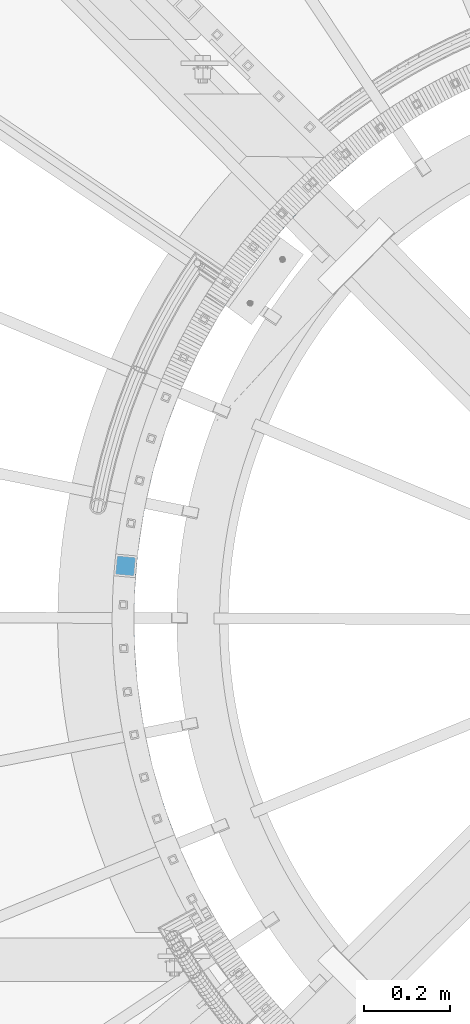
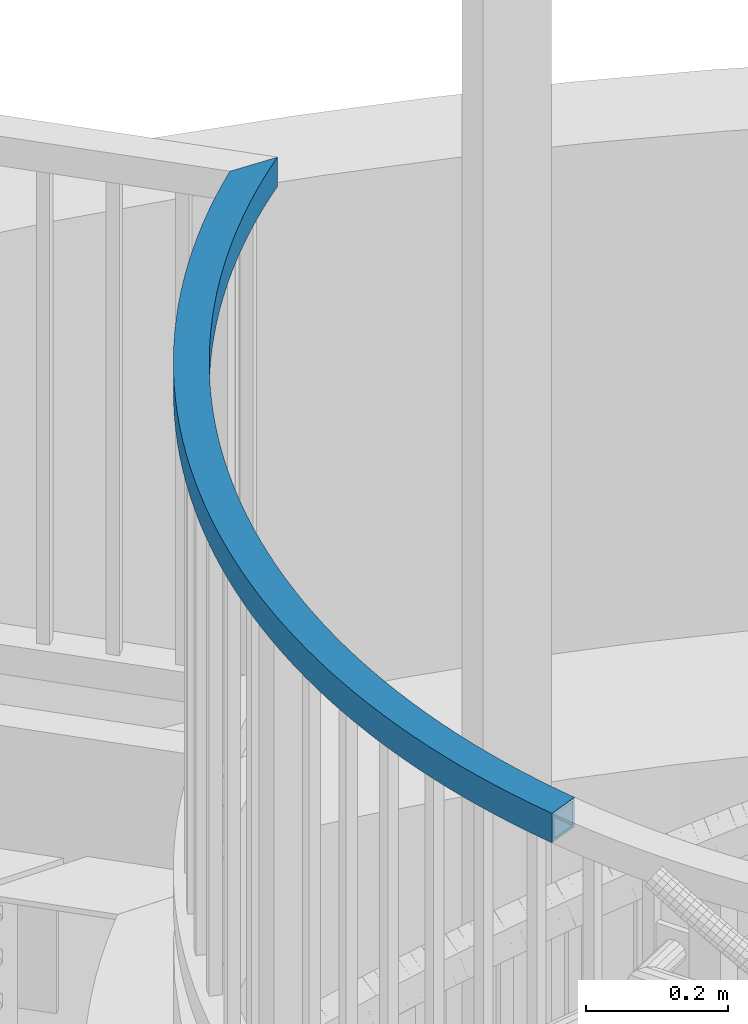
# One storey, part 344 of 975: 1 beam.
"""IFC2X3 building model written with IfcOpenShell, lengths in millimetres."""

from ifc_helpers import new_model, si_unit, frame, origin_with_axes, place, context, subcontext, project, spatial, faceted_brep, material, type_object, element, save


model = new_model("IFC2X3")

# Units and contexts
model_context = context("Model", 3, precision=1e-05, world=origin_with_axes())
body_context = subcontext(model_context, "Body", "Model", "MODEL_VIEW")
ifc_project = project(units=[si_unit("LENGTHUNIT", "METRE", prefix="MILLI"), si_unit("AREAUNIT", "SQUARE_METRE"), si_unit("VOLUMEUNIT", "CUBIC_METRE"), si_unit("MASSUNIT", "GRAM", prefix="KILO"), si_unit("TIMEUNIT", "SECOND"), si_unit("PLANEANGLEUNIT", "RADIAN"), si_unit("SOLIDANGLEUNIT", "STERADIAN"), si_unit("THERMODYNAMICTEMPERATUREUNIT", "DEGREE_CELSIUS"), si_unit("LUMINOUSINTENSITYUNIT", "LUMEN")], contexts=[model_context])

# Site, building, storey
site_placement = place(None, origin_with_axes())
site = spatial("IfcSite", under=ifc_project, at=site_placement, CompositionType="ELEMENT")
building_placement = place(site_placement, origin_with_axes())
building = spatial("IfcBuilding", under=site, at=building_placement, Name="Undefined", CompositionType="ELEMENT")
storey_placement = place(building_placement, origin_with_axes())
storey = spatial("IfcBuildingStorey", under=building, at=storey_placement, Name="Undefined", CompositionType="ELEMENT", Elevation=0.0)

# Beam
ifc_material = material()
beam_type = type_object("IfcBeamType", Name="HSS2X2X.188_TUBES", PredefinedType="NOTDEFINED")
beam_placement = place(storey_placement, frame((33433.8380151648, 2893.80847219142, 5130.8), z_axis=(0.0, 0.0, 1.0), x_axis=(0.321150340924358, 0.947028224776943, 0.0)))
element("IfcBeam", 1, at=beam_placement, inside=storey, type_object=beam_type, material=ifc_material, Name="HANDRAIL", ObjectType="HSS2X2X.188_TUBES", context=body_context, shape_type="Brep", body=[
    faceted_brep([(1598.93336407452, 112.409592941978, 25.3999999999996), (1598.93336407452, 112.409592941978, -25.3999999999996), (1626.76418138744, 95.4936685589528, -25.3999999999996), (1626.76418138744, 95.4936685589528, 25.3999999999996), (1570.70875476768, 128.659956615276, 25.3999999999996), (1570.70875476768, 128.659956615276, -25.3999999999996), (1542.10626700468, 144.23559733418, 25.3999999999996), (1542.10626700468, 144.23559733418, -25.3999999999996), (1513.14202737783, 159.127733274894, 25.3999999999996), (1513.14202737783, 159.127733274894, -25.3999999999996), (1483.83236644166, 173.327967985762, 25.3999999999996), (1483.83236644166, 173.327967985762, -25.3999999999996), (1454.19380950532, 186.828295121384, 25.3999999999996), (1454.19380950532, 186.828295121384, -25.3999999999996), (1424.24306731543, 199.62110295672, 25.3999999999996), (1424.24306731543, 199.62110295672, -25.3999999999996), (1393.9970266342, 211.699178678729, 25.3999999999996), (1393.9970266342, 211.699178678729, -25.3999999999996), (1363.47274071841, 223.055712453068, 25.3999999999996), (1363.47274071841, 223.055712453068, -25.3999999999996), (1332.68741970443, 233.684301263602, 25.3999999999996), (1332.68741970443, 233.684301263602, -25.3999999999996), (1301.65842090491, 243.578952522545, 25.3999999999996), (1301.65842090491, 243.578952522545, -25.3999999999996), (1270.40323902235, 252.734087449178, 25.3999999999996), (1270.40323902235, 252.734087449178, -25.3999999999996), (1238.93949628531, 261.144544215262, 25.3999999999996), (1238.93949628531, 261.144544215262, -25.3999999999996), (1207.28493251269, 268.805580855405, 25.3999999999996), (1207.28493251269, 268.805580855405, -25.3999999999996), (1175.45739511167, 275.712877940594, 25.3999999999996), (1175.45739511167, 275.712877940594, -25.3999999999996), (1143.47482901506, 281.862541013641, 25.3999999999996), (1143.47482901506, 281.862541013641, -25.3999999999996), (1111.35526656359, 287.251102784918, 25.3999999999996), (1111.35526656359, 287.251102784918, -25.3999999999996), (1079.11681733901, 291.875525087253, 25.3999999999996), (1079.11681733901, 291.875525087253, -25.3999999999996), (1046.77765795353, 295.733200588944, 25.3999999999996), (1046.77765795353, 295.733200588944, -25.3999999999996), (1014.35602180154, 298.8219542638, 25.3999999999996), (1014.35602180154, 298.8219542638, -25.3999999999996), (981.87018877931, 301.140044617438, 25.3999999999996), (981.87018877931, 301.140044617438, -25.3999999999996), (949.338474978445, 302.686164669216, 25.3999999999996), (949.338474978445, 302.686164669216, -25.3999999999996), (916.77922235896, 303.45944268908, 25.3999999999996), (916.77922235896, 303.45944268908, -25.3999999999996), (884.210788407729, 303.459442689124, 25.3999999999996), (884.210788407729, 303.459442689124, -25.3999999999996), (851.651535788242, 302.686164669329, 25.3999999999996), (851.651535788242, 302.686164669329, -25.3999999999996), (819.11982198738, 301.14004461763, 25.3999999999996), (819.11982198738, 301.14004461763, -25.3999999999996), (786.633988965152, 298.821954264073, 25.3999999999996), (786.633988965152, 298.821954264073, -25.3999999999996), (754.212352813165, 295.733200589297, 25.3999999999996), (754.212352813165, 295.733200589297, -25.3999999999996), (721.873193427688, 291.875525087682, 25.3999999999996), (721.873193427688, 291.875525087682, -25.3999999999996), (689.634744203111, 287.25110278542, 25.3999999999996), (689.634744203111, 287.25110278542, -25.3999999999996), (657.515181751656, 281.862541014216, 25.3999999999996), (657.515181751656, 281.862541014216, -25.3999999999996), (625.532615655047, 275.712877941245, 25.3999999999996), (625.532615655047, 275.712877941245, -25.3999999999996), (593.705078254034, 268.805580856129, 25.3999999999996), (593.705078254034, 268.805580856129, -25.3999999999996), (562.050514481421, 261.144544216066, 25.3999999999996), (562.050514481421, 261.144544216066, -25.3999999999996), (530.586771744394, 252.734087450059, 25.3999999999996), (530.586771744394, 252.734087450059, -25.3999999999996), (499.331589861844, 243.578952523494, 25.3999999999996), (499.331589861844, 243.578952523494, -25.3999999999996), (468.302591062333, 233.684301264624, 25.3999999999996), (468.302591062333, 233.684301264624, -25.3999999999996), (437.517270048369, 223.055712454166, 25.3999999999996), (437.517270048369, 223.055712454166, -25.3999999999996), (406.992984132585, 211.699178679897, 25.3999999999996), (406.992984132585, 211.699178679897, -25.3999999999996), (376.74694345137, 199.621102957961, 25.3999999999996), (376.74694345137, 199.621102957961, -25.3999999999996), (346.796201261493, 186.828295122694, 25.3999999999996), (346.796201261493, 186.828295122694, -25.3999999999996), (317.157644325169, 173.327967987148, 25.3999999999996), (317.157644325169, 173.327967987148, -25.3999999999996), (287.847983389005, 159.127733276349, 25.3999999999996), (287.847983389005, 159.127733276349, -25.3999999999996), (258.883743762184, 144.235597335708, 25.3999999999996), (258.883743762184, 144.235597335708, -25.3999999999996), (230.281255999194, 128.659956616866, 25.3999999999996), (230.281255999194, 128.659956616866, -25.3999999999996), (202.056646692379, 112.409592943641, 25.3999999999996), (202.056646692379, 112.409592943641, -25.3999999999996), (174.225829379473, 95.4936685606808, 25.3999999999996), (174.225829379473, 95.4936685606808, -25.3999999999996), (146.804495571261, 77.9217209676208, 25.3999999999996), (146.804495571261, 77.9217209676208, -25.3999999999996), (119.808105904445, 59.7036575416751, 25.3999999999996), (119.808105904445, 59.7036575416751, -25.3999999999996), (93.2518814246323, 40.8497499516743, 25.3999999999996), (93.2518814246323, 40.8497499516743, -25.3999999999996), (67.1507950044543, 21.3706283667307, 25.3999999999996), (67.1507950044543, 21.3706283667307, -25.3999999999996), (41.5195629016052, 1.27727546274036, 25.3999999999996), (41.5195629016052, 1.27727546274036, -25.3999999999996), (16.3726364615322, -19.4189797698346, 25.3999999999996), (16.3726364615322, -19.4189797698346, -25.3999999999996), (-16.3726364615268, 19.4189797698236, -25.3999999999996), (9.70565762447586, 40.8817629739824, -25.3999999999996), (36.2861946200246, 61.719314133672, -25.3999999999996), (63.3539879446489, 81.9198846662111, -25.3999999999996), (90.8937762940877, 101.47208512991, -25.3999999999996), (118.890032244861, 120.36489164571, -25.3999999999996), (147.326971008932, 138.587652112579, -25.3999999999996), (176.188559333428, 156.130092213429, -25.3999999999996), (205.458524540496, 172.982321207885, -25.3999999999996), (235.120363702115, 189.134837508904, -25.3999999999996), (265.157352944745, 204.578534039942, -25.3999999999996), (295.552556878542, 219.304703369657, -25.3999999999996), (326.28883814584, 233.305042621338, -25.3999999999996), (357.34886708349, 246.571658154207, -25.3999999999996), (388.715131493642, 259.097070013991, -25.3999999999996), (420.369946517416, 270.874216150271, -25.3999999999996), (452.295464605973, 281.896456398157, -25.3999999999996), (484.473685583242, 292.157576222173, -25.3999999999996), (516.886466794776, 301.651790220079, -25.3999999999996), (549.515533336877, 310.373745384844, -25.3999999999996), (582.342488360329, 318.318524122682, -25.3999999999996), (615.348823442862, 325.481647025761, -25.3999999999996), (648.515929024528, 331.859075397733, -25.3999999999996), (681.825104900112, 337.447213530824, -25.3999999999996), (715.257570762635, 342.242910733174, -25.3999999999996), (748.79447679202, 346.24346310522, -25.3999999999996), (782.416914282971, 349.44661506424, -25.3999999999996), (816.105926306022, 351.850560616087, -25.3999999999996), (849.842518395802, 353.453944373407, -25.3999999999996), (883.607669260458, 354.255862319857, -25.3999999999996), (917.382341506178, 354.255862319813, -25.3999999999996), (951.14749237083, 353.453944373279, -25.3999999999996), (984.884084460617, 351.850560615887, -25.3999999999996), (1018.57309648367, 349.446615063967, -25.3999999999996), (1052.19553397462, 346.24346310486, -25.3999999999996), (1085.73244000401, 342.242910732733, -25.3999999999996), (1119.16490586654, 337.447213530304, -25.3999999999996), (1152.47408174213, 331.859075397133, -25.3999999999996), (1185.6411873238, 325.481647025081, -25.3999999999996), (1218.64752240634, 318.318524121925, -25.3999999999996), (1251.47447742981, 310.373745384008, -25.3999999999996), (1284.10354397191, 301.651790219174, -25.3999999999996), (1316.51632518346, 292.157576221187, -25.3999999999996), (1348.69454616074, 281.896456397099, -25.3999999999996), (1380.62006424931, 270.874216149132, -25.3999999999996), (1412.2748792731, 259.09707001278, -25.3999999999996), (1443.64114368326, 246.571658152916, -25.3999999999996), (1474.70117262092, 233.305042619977, -25.3999999999996), (1505.43745388824, 219.304703368216, -25.3999999999996), (1535.83265782205, 204.578534038435, -25.3999999999996), (1565.8696470647, 189.134837507328, -25.3999999999996), (1595.53148622633, 172.982321206233, -25.3999999999996), (1623.75236658256, 156.734104482184, -25.3999999999996), (1644.72069833999, 83.9868987915906, -25.3999999999996), (1644.72069833999, 83.9868987915906, 25.3999999999996), (1595.53148622633, 172.982321206233, 25.3999999999996), (1565.8696470647, 189.134837507328, 25.3999999999996), (1535.83265782205, 204.578534038435, 25.3999999999996), (1505.43745388824, 219.304703368216, 25.3999999999996), (1474.70117262092, 233.305042619977, 25.3999999999996), (1443.64114368326, 246.571658152916, 25.3999999999996), (1412.2748792731, 259.09707001278, 25.3999999999996), (1380.62006424931, 270.874216149132, 25.3999999999996), (1348.69454616074, 281.896456397099, 25.3999999999996), (1316.51632518346, 292.157576221187, 25.3999999999996), (1284.10354397191, 301.651790219174, 25.3999999999996), (1251.47447742981, 310.373745384008, 25.3999999999996), (1218.64752240634, 318.318524121925, 25.3999999999996), (1185.6411873238, 325.481647025081, 25.3999999999996), (1152.47408174213, 331.859075397133, 25.3999999999996), (1119.16490586654, 337.447213530304, 25.3999999999996), (1085.73244000401, 342.242910732733, 25.3999999999996), (1052.19553397462, 346.24346310486, 25.3999999999996), (1018.57309648367, 349.446615063967, 25.3999999999996), (984.884084460617, 351.850560615887, 25.3999999999996), (951.14749237083, 353.453944373279, 25.3999999999996), (917.382341506178, 354.255862319813, 25.3999999999996), (883.607669260458, 354.255862319857, 25.3999999999996), (849.842518395802, 353.453944373407, 25.3999999999996), (816.105926306022, 351.850560616087, 25.3999999999996), (782.416914282971, 349.44661506424, 25.3999999999996), (748.79447679202, 346.24346310522, 25.3999999999996), (715.257570762635, 342.242910733174, 25.3999999999996), (681.825104900112, 337.447213530824, 25.3999999999996), (648.515929024528, 331.859075397733, 25.3999999999996), (615.348823442862, 325.481647025761, 25.3999999999996), (582.342488360329, 318.318524122682, 25.3999999999996), (549.515533336877, 310.373745384844, 25.3999999999996), (516.886466794776, 301.651790220079, 25.3999999999996), (484.473685583242, 292.157576222173, 25.3999999999996), (452.295464605973, 281.896456398157, 25.3999999999996), (420.369946517416, 270.874216150271, 25.3999999999996), (388.715131493642, 259.097070013991, 25.3999999999996), (357.34886708349, 246.571658154207, 25.3999999999996), (326.28883814584, 233.305042621338, 25.3999999999996), (295.552556878542, 219.304703369657, 25.3999999999996), (265.157352944745, 204.578534039942, 25.3999999999996), (235.120363702115, 189.134837508904, 25.3999999999996), (205.458524540496, 172.982321207885, 25.3999999999996), (176.188559333428, 156.130092213429, 25.3999999999996), (147.326971008932, 138.587652112579, 25.3999999999996), (118.890032244861, 120.36489164571, 25.3999999999996), (90.8937762940877, 101.47208512991, 25.3999999999996), (63.3539879446489, 81.9198846662111, 25.3999999999996), (36.2861946200246, 61.719314133672, 25.3999999999996), (9.70565762447586, 40.8817629739824, 25.3999999999996), (-16.3726364615268, 19.4189797698236, 25.3999999999996), (1623.75236658256, 156.734104482184, 25.3999999999996), (1593.20435515209, 168.827099525828, 20.6374999999998), (1593.20435515209, 168.827099525828, -20.6374999999998), (1622.37631824352, 152.031295405173, -20.6374999999998), (1622.37631824352, 152.031295405173, 20.6374999999998), (1563.64183018407, 184.925533741094, 20.6374999999998), (1563.64183018407, 184.925533741094, -20.6374999999998), (1533.70541121791, 200.317521466855, 20.6374999999998), (1533.70541121791, 200.317521466855, -20.6374999999998), (1503.41197694012, 214.994384426118, 20.6374999999998), (1503.41197694012, 214.994384426118, -20.6374999999998), (1472.77860732883, 228.947847541986, 20.6374999999998), (1472.77860732883, 228.947847541986, -20.6374999999998), (1441.82257402377, 242.170043603273, 20.6374999999998), (1441.82257402377, 242.170043603273, -20.6374999999998), (1410.5613305882, 254.653517700208, 20.6374999999998), (1410.5613305882, 254.653517700208, -20.6374999999998), (1379.01250266828, 266.391231427628, 20.6374999999998), (1379.01250266828, 266.391231427628, -20.6374999999998), (1347.19387805546, 277.376566853331, 20.6374999999998), (1347.19387805546, 277.376566853331, -20.6374999999998), (1315.12339665735, 287.603330249436, 20.6374999999998), (1315.12339665735, 287.603330249436, -20.6374999999998), (1282.81914038289, 297.065755584485, 20.6374999999998), (1282.81914038289, 297.065755584485, -20.6374999999998), (1250.29932294751, 305.758507774437, 20.6374999999998), (1250.29932294751, 305.758507774437, -20.6374999999998), (1217.58227960381, 313.676685690683, 20.6374999999998), (1217.58227960381, 313.676685690683, -20.6374999999998), (1184.68645680392, 320.815824923411, 20.6374999999998), (1184.68645680392, 320.815824923411, -20.6374999999998), (1151.63040179897, 327.171900298683, 20.6374999999998), (1151.63040179897, 327.171900298683, -20.6374999999998), (1118.43275218189, 332.741328147931, 20.6374999999998), (1118.43275218189, 332.741328147931, -20.6374999999998), (1085.11222537917, 337.52096832847, 20.6374999999998), (1085.11222537917, 337.52096832847, -20.6374999999998), (1051.68760809765, 341.508125993994, 20.6374999999998), (1051.68760809765, 341.508125993994, -20.6374999999998), (1018.17774573222, 344.700553113948, 20.6374999999998), (1018.17774573222, 344.700553113948, -20.6374999999998), (984.601531740493, 347.096449741031, 20.6374999999998), (984.601531740493, 347.096449741031, -20.6374999999998), (950.977896990295, 348.69446502603, 20.6374999999998), (950.977896990295, 348.69446502603, -20.6374999999998), (917.325799086124, 349.493697979433, 20.6374999999998), (917.325799086124, 349.493697979433, -20.6374999999998), (883.664211680512, 349.493697979477, 20.6374999999998), (883.664211680512, 349.493697979477, -20.6374999999998), (850.012113776344, 348.694465026147, 20.6374999999998), (850.012113776344, 348.694465026147, -20.6374999999998), (816.388479026149, 347.096449741228, 20.6374999999998), (816.388479026149, 347.096449741228, -20.6374999999998), (782.812265034425, 344.700553114228, 20.6374999999998), (782.812265034425, 344.700553114228, -20.6374999999998), (749.302402669002, 341.508125994351, 20.6374999999998), (749.302402669002, 341.508125994351, -20.6374999999998), (715.877785387484, 337.52096832891, 20.6374999999998), (715.877785387484, 337.52096832891, -20.6374999999998), (682.557258584769, 332.741328148444, 20.6374999999998), (682.557258584769, 332.741328148444, -20.6374999999998), (649.359608967698, 327.171900299276, 20.6374999999998), (649.359608967698, 327.171900299276, -20.6374999999998), (616.303553962754, 320.815824924084, 20.6374999999998), (616.303553962754, 320.815824924084, -20.6374999999998), (583.407731162864, 313.676685691436, 20.6374999999998), (583.407731162864, 313.676685691436, -20.6374999999998), (550.690687819177, 305.758507775266, 20.6374999999998), (550.690687819177, 305.758507775266, -20.6374999999998), (518.170870383803, 297.06575558539, 20.6374999999998), (518.170870383803, 297.06575558539, -20.6374999999998), (485.86661410936, 287.603330250422, 20.6374999999998), (485.86661410936, 287.603330250422, -20.6374999999998), (453.796132711255, 277.376566854389, 20.6374999999998), (453.796132711255, 277.376566854389, -20.6374999999998), (421.977508098444, 266.391231428759, 20.6374999999998), (421.977508098444, 266.391231428759, -20.6374999999998), (390.428680178542, 254.653517701419, 20.6374999999998), (390.428680178542, 254.653517701419, -20.6374999999998), (359.16743674298, 242.170043604561, 20.6374999999998), (359.16743674298, 242.170043604561, -20.6374999999998), (328.211403437932, 228.947847543343, 20.6374999999998), (328.211403437932, 228.947847543343, -20.6374999999998), (297.578033826665, 214.994384427544, 20.6374999999998), (297.578033826665, 214.994384427544, -20.6374999999998), (267.284599548895, 200.317521468354, 20.6374999999998), (267.284599548895, 200.317521468354, -20.6374999999998), (237.348180582747, 184.925533742669, 20.6374999999998), (237.348180582747, 184.925533742669, -20.6374999999998), (207.785655614751, 168.827099527472, 20.6374999999998), (207.785655614751, 168.827099527472, -20.6374999999998), (178.61369252333, 152.031295406887, 20.6374999999998), (178.61369252333, 152.031295406887, -20.6374999999998), (149.848738981169, 134.547591154595, 20.6374999999998), (149.848738981169, 134.547591154595, -20.6374999999998), (121.50701318171, 116.385844394637, 20.6374999999998), (121.50701318171, 116.385844394637, -20.6374999999998), (93.6044946950587, 97.5562950435124, 20.6374999999998), (93.6044946950587, 97.5562950435124, -20.6374999999998), (66.1569154583976, 78.0695595367251, 20.6374999999998), (66.1569154583976, 78.0695595367251, -20.6374999999998), (39.1797509060652, 57.9366248430233, 20.6374999999998), (39.1797509060652, 57.9366248430233, -20.6374999999998), (12.6882112442072, 37.1688422697989, 20.6374999999998), (12.6882112442072, 37.1688422697989, -20.6374999999998), (-13.3027671249893, 15.7779210629815, 20.6374999999998), (-13.3027671249893, 15.7779210629815, -20.6374999999998), (13.3027671249947, -15.7779210629924, 20.6374999999998), (13.3027671249947, -15.7779210629924, -20.6374999999998), (38.5370092818739, 4.99019616691658, 20.6374999999998), (38.5370092818739, 4.99019616691658, -20.6374999999998), (64.2572387184155, 25.153317657383, 20.6374999999998), (64.2572387184155, 25.153317657383, -20.6374999999998), (90.4489539108799, 44.7000750811676, 20.6374999999998), (90.4489539108799, 44.7000750811676, -20.6374999999998), (117.097387503472, 63.6194476280689, 20.6374999999998), (117.097387503472, 63.6194476280689, -20.6374999999998), (144.187514634414, 81.9007682186893, 20.6374999999998), (144.187514634414, 81.9007682186893, -20.6374999999998), (171.704061407236, 99.5337295186655, 20.6374999999998), (171.704061407236, 99.5337295186655, -20.6374999999998), (199.631513502478, 116.508389750179, 20.6374999999998), (199.631513502478, 116.508389750179, -20.6374999999998), (227.954124924943, 132.815178297271, 20.6374999999998), (227.954124924943, 132.815178297271, -20.6374999999998), (256.655926881554, 148.444901101942, 20.6374999999998), (256.655926881554, 148.444901101942, -20.6374999999998), (285.720736784857, 163.388745847933, 20.6374999999998), (285.720736784857, 163.388745847933, -20.6374999999998), (315.132167377049, 177.638286929254, 20.6374999999998), (315.132167377049, 177.638286929254, -20.6374999999998), (344.873635969399, 191.185490200693, 20.6374999999998), (344.873635969399, 191.185490200693, -20.6374999999998), (374.928373791883, 204.022717507607, 20.6374999999998), (374.928373791883, 204.022717507607, -20.6374999999998), (405.279435447685, 216.142730992466, 20.6374999999998), (405.279435447685, 216.142730992466, -20.6374999999998), (435.909708467343, 227.538697175674, 20.6374999999998), (435.909708467343, 227.538697175674, -20.6374999999998), (466.801922957049, 238.204190808396, 20.6374999999998), (466.801922957049, 238.204190808396, -20.6374999999998), (497.938661335726, 248.133198495245, 20.6374999999998), (497.938661335726, 248.133198495245, -20.6374999999998), (529.302368155368, 257.320122084748, 20.6374999999998), (529.302368155368, 257.320122084748, -20.6374999999998), (560.87535999912, 265.759781825644, 20.6374999999998), (560.87535999912, 265.759781825644, -20.6374999999998), (592.6398354515, 273.447419287368, 20.6374999999998), (592.6398354515, 273.447419287368, -20.6374999999998), (624.577885135155, 280.378700042918, 20.6374999999998), (624.577885135155, 280.378700042918, -20.6374999999998), (656.671501808487, 286.549716112673, 20.6374999999998), (656.671501808487, 286.549716112673, -20.6374999999998), (688.902590518455, 291.9569881678, 20.6374999999998), (688.902590518455, 291.9569881678, -20.6374999999998), (721.252978802837, 296.597467491942, 20.6374999999998), (721.252978802837, 296.597467491942, -20.6374999999998), (753.704426936183, 300.468537700162, 20.6374999999998), (753.704426936183, 300.468537700162, -20.6374999999998), (786.238638213699, 303.568016214085, 20.6374999999998), (786.238638213699, 303.568016214085, -20.6374999999998), (818.837269267253, 305.894155492482, 20.6374999999998), (818.837269267253, 305.894155492482, -20.6374999999998), (851.481940407701, 307.445644016589, 20.6374999999998), (851.481940407701, 307.445644016589, -20.6374999999998), (884.154245987673, 308.2216070295, 20.6374999999998), (884.154245987673, 308.2216070295, -20.6374999999998), (916.835764779011, 308.221607029467, 20.6374999999998), (916.835764779011, 308.221607029467, -20.6374999999998), (949.508070358985, 307.445644016465, 20.6374999999998), (949.508070358985, 307.445644016465, -20.6374999999998), (982.152741499434, 305.894155492293, 20.6374999999998), (982.152741499434, 305.894155492293, -20.6374999999998), (1014.75137255299, 303.568016213812, 20.6374999999998), (1014.75137255299, 303.568016213812, -20.6374999999998), (1047.28558383051, 300.468537699817, 20.6374999999998), (1047.28558383051, 300.468537699817, -20.6374999999998), (1079.73703196386, 296.597467491516, 20.6374999999998), (1079.73703196386, 296.597467491516, -20.6374999999998), (1112.08742024824, 291.956988167298, 20.6374999999998), (1112.08742024824, 291.956988167298, -20.6374999999998), (1144.31850895822, 286.549716112091, 20.6374999999998), (1144.31850895822, 286.549716112091, -20.6374999999998), (1176.41212563156, 280.378700042267, 20.6374999999998), (1176.41212563156, 280.378700042267, -20.6374999999998), (1208.35017531522, 273.447419286636, 20.6374999999998), (1208.35017531522, 273.447419286636, -20.6374999999998), (1240.11465076761, 265.759781824836, 20.6374999999998), (1240.11465076761, 265.759781824836, -20.6374999999998), (1271.68764261137, 257.320122083864, 20.6374999999998), (1271.68764261137, 257.320122083864, -20.6374999999998), (1303.05134943102, 248.133198494295, 20.6374999999998), (1303.05134943102, 248.133198494295, -20.6374999999998), (1334.18808780971, 238.204190807362, 20.6374999999998), (1334.18808780971, 238.204190807362, -20.6374999999998), (1365.08030229943, 227.538697174572, 20.6374999999998), (1365.08030229943, 227.538697174572, -20.6374999999998), (1395.7105753191, 216.142730991291, 20.6374999999998), (1395.7105753191, 216.142730991291, -20.6374999999998), (1426.06163697492, 204.022717506363, 20.6374999999998), (1426.06163697492, 204.022717506363, -20.6374999999998), (1456.11637479741, 191.185490199376, 20.6374999999998), (1456.11637479741, 191.185490199376, -20.6374999999998), (1485.85784338978, 177.63828692786, 20.6374999999998), (1485.85784338978, 177.63828692786, -20.6374999999998), (1515.26927398198, 163.388745846478, 20.6374999999998), (1515.26927398198, 163.388745846478, -20.6374999999998), (1544.3340838853, 148.444901100418, 20.6374999999998), (1544.3340838853, 148.444901100418, -20.6374999999998), (1573.03588584193, 132.815178295677, 20.6374999999998), (1573.03588584193, 132.815178295677, -20.6374999999998), (1601.35849726441, 116.50838974852, 20.6374999999998), (1601.35849726441, 116.50838974852, -20.6374999999998), (1629.28594935968, 99.5337295169411, 20.6374999999998), (1629.28594935968, 99.5337295169411, -20.6374999999998), (1642.72108734282, 90.9243182389437, 20.6374999999998), (1642.72108734282, 90.9243182389437, -20.6374999999998), (1625.6880820195, 150.018363302643, -20.6374999999998), (1625.6880820195, 150.018363302643, 20.6374999999998)], [[[0, 1, 2, 3]], [[4, 5, 1, 0]], [[6, 7, 5, 4]], [[8, 9, 7, 6]], [[10, 11, 9, 8]], [[12, 13, 11, 10]], [[14, 15, 13, 12]], [[16, 17, 15, 14]], [[18, 19, 17, 16]], [[20, 21, 19, 18]], [[22, 23, 21, 20]], [[24, 25, 23, 22]], [[26, 27, 25, 24]], [[28, 29, 27, 26]], [[30, 31, 29, 28]], [[32, 33, 31, 30]], [[34, 35, 33, 32]], [[36, 37, 35, 34]], [[38, 39, 37, 36]], [[40, 41, 39, 38]], [[42, 43, 41, 40]], [[44, 45, 43, 42]], [[46, 47, 45, 44]], [[48, 49, 47, 46]], [[50, 51, 49, 48]], [[52, 53, 51, 50]], [[54, 55, 53, 52]], [[56, 57, 55, 54]], [[58, 59, 57, 56]], [[60, 61, 59, 58]], [[62, 63, 61, 60]], [[64, 65, 63, 62]], [[66, 67, 65, 64]], [[68, 69, 67, 66]], [[70, 71, 69, 68]], [[72, 73, 71, 70]], [[74, 75, 73, 72]], [[76, 77, 75, 74]], [[78, 79, 77, 76]], [[80, 81, 79, 78]], [[82, 83, 81, 80]], [[84, 85, 83, 82]], [[86, 87, 85, 84]], [[88, 89, 87, 86]], [[90, 91, 89, 88]], [[92, 93, 91, 90]], [[94, 95, 93, 92]], [[96, 97, 95, 94]], [[98, 99, 97, 96]], [[100, 101, 99, 98]], [[102, 103, 101, 100]], [[104, 105, 103, 102]], [[106, 107, 105, 104]], [[2, 1, 5, 7, 9, 11, 13, 15, 17, 19, 21, 23, 25, 27, 29, 31, 33, 35, 37, 39, 41, 43, 45, 47, 49, 51, 53, 55, 57, 59, 61, 63, 65, 67, 69, 71, 73, 75, 77, 79, 81, 83, 85, 87, 89, 91, 93, 95, 97, 99, 101, 103, 105, 107, 108, 109, 110, 111, 112, 113, 114, 115, 116, 117, 118, 119, 120, 121, 122, 123, 124, 125, 126, 127, 128, 129, 130, 131, 132, 133, 134, 135, 136, 137, 138, 139, 140, 141, 142, 143, 144, 145, 146, 147, 148, 149, 150, 151, 152, 153, 154, 155, 156, 157, 158, 159, 160, 161]], [[3, 2, 161, 162]], [[163, 164, 165, 166, 167, 168, 169, 170, 171, 172, 173, 174, 175, 176, 177, 178, 179, 180, 181, 182, 183, 184, 185, 186, 187, 188, 189, 190, 191, 192, 193, 194, 195, 196, 197, 198, 199, 200, 201, 202, 203, 204, 205, 206, 207, 208, 209, 210, 211, 212, 213, 214, 106, 104, 102, 100, 98, 96, 94, 92, 90, 88, 86, 84, 82, 80, 78, 76, 74, 72, 70, 68, 66, 64, 62, 60, 58, 56, 54, 52, 50, 48, 46, 44, 42, 40, 38, 36, 34, 32, 30, 28, 26, 24, 22, 20, 18, 16, 14, 12, 10, 8, 6, 4, 0, 3, 162, 215]], [[159, 163, 215, 160]], [[158, 164, 163, 159]], [[157, 165, 164, 158]], [[156, 166, 165, 157]], [[155, 167, 166, 156]], [[154, 168, 167, 155]], [[153, 169, 168, 154]], [[152, 170, 169, 153]], [[151, 171, 170, 152]], [[150, 172, 171, 151]], [[149, 173, 172, 150]], [[148, 174, 173, 149]], [[147, 175, 174, 148]], [[146, 176, 175, 147]], [[145, 177, 176, 146]], [[144, 178, 177, 145]], [[143, 179, 178, 144]], [[142, 180, 179, 143]], [[141, 181, 180, 142]], [[140, 182, 181, 141]], [[139, 183, 182, 140]], [[138, 184, 183, 139]], [[137, 185, 184, 138]], [[136, 186, 185, 137]], [[135, 187, 186, 136]], [[134, 188, 187, 135]], [[133, 189, 188, 134]], [[132, 190, 189, 133]], [[131, 191, 190, 132]], [[130, 192, 191, 131]], [[129, 193, 192, 130]], [[128, 194, 193, 129]], [[127, 195, 194, 128]], [[126, 196, 195, 127]], [[125, 197, 196, 126]], [[124, 198, 197, 125]], [[123, 199, 198, 124]], [[122, 200, 199, 123]], [[121, 201, 200, 122]], [[120, 202, 201, 121]], [[119, 203, 202, 120]], [[118, 204, 203, 119]], [[117, 205, 204, 118]], [[116, 206, 205, 117]], [[115, 207, 206, 116]], [[114, 208, 207, 115]], [[113, 209, 208, 114]], [[112, 210, 209, 113]], [[111, 211, 210, 112]], [[110, 212, 211, 111]], [[109, 213, 212, 110]], [[108, 214, 213, 109]], [[216, 217, 218, 219]], [[220, 221, 217, 216]], [[222, 223, 221, 220]], [[224, 225, 223, 222]], [[226, 227, 225, 224]], [[228, 229, 227, 226]], [[230, 231, 229, 228]], [[232, 233, 231, 230]], [[234, 235, 233, 232]], [[236, 237, 235, 234]], [[238, 239, 237, 236]], [[240, 241, 239, 238]], [[242, 243, 241, 240]], [[244, 245, 243, 242]], [[246, 247, 245, 244]], [[248, 249, 247, 246]], [[250, 251, 249, 248]], [[252, 253, 251, 250]], [[254, 255, 253, 252]], [[256, 257, 255, 254]], [[258, 259, 257, 256]], [[260, 261, 259, 258]], [[262, 263, 261, 260]], [[264, 265, 263, 262]], [[266, 267, 265, 264]], [[268, 269, 267, 266]], [[270, 271, 269, 268]], [[272, 273, 271, 270]], [[274, 275, 273, 272]], [[276, 277, 275, 274]], [[278, 279, 277, 276]], [[280, 281, 279, 278]], [[282, 283, 281, 280]], [[284, 285, 283, 282]], [[286, 287, 285, 284]], [[288, 289, 287, 286]], [[290, 291, 289, 288]], [[292, 293, 291, 290]], [[294, 295, 293, 292]], [[296, 297, 295, 294]], [[298, 299, 297, 296]], [[300, 301, 299, 298]], [[302, 303, 301, 300]], [[304, 305, 303, 302]], [[306, 307, 305, 304]], [[308, 309, 307, 306]], [[310, 311, 309, 308]], [[312, 313, 311, 310]], [[314, 315, 313, 312]], [[316, 317, 315, 314]], [[318, 319, 317, 316]], [[320, 321, 319, 318]], [[107, 106, 214, 108], [320, 322, 323, 321]], [[323, 322, 324, 325]], [[325, 324, 326, 327]], [[327, 326, 328, 329]], [[329, 328, 330, 331]], [[331, 330, 332, 333]], [[333, 332, 334, 335]], [[335, 334, 336, 337]], [[337, 336, 338, 339]], [[339, 338, 340, 341]], [[341, 340, 342, 343]], [[343, 342, 344, 345]], [[345, 344, 346, 347]], [[347, 346, 348, 349]], [[349, 348, 350, 351]], [[351, 350, 352, 353]], [[353, 352, 354, 355]], [[355, 354, 356, 357]], [[357, 356, 358, 359]], [[359, 358, 360, 361]], [[361, 360, 362, 363]], [[363, 362, 364, 365]], [[365, 364, 366, 367]], [[367, 366, 368, 369]], [[369, 368, 370, 371]], [[371, 370, 372, 373]], [[373, 372, 374, 375]], [[375, 374, 376, 377]], [[377, 376, 378, 379]], [[379, 378, 380, 381]], [[381, 380, 382, 383]], [[383, 382, 384, 385]], [[385, 384, 386, 387]], [[387, 386, 388, 389]], [[389, 388, 390, 391]], [[391, 390, 392, 393]], [[393, 392, 394, 395]], [[395, 394, 396, 397]], [[397, 396, 398, 399]], [[399, 398, 400, 401]], [[401, 400, 402, 403]], [[403, 402, 404, 405]], [[405, 404, 406, 407]], [[407, 406, 408, 409]], [[409, 408, 410, 411]], [[411, 410, 412, 413]], [[413, 412, 414, 415]], [[415, 414, 416, 417]], [[417, 416, 418, 419]], [[419, 418, 420, 421]], [[421, 420, 422, 423]], [[423, 422, 424, 425]], [[425, 424, 426, 427]], [[427, 426, 428, 429]], [[429, 428, 430, 431]], [[218, 217, 221, 223, 225, 227, 229, 231, 233, 235, 237, 239, 241, 243, 245, 247, 249, 251, 253, 255, 257, 259, 261, 263, 265, 267, 269, 271, 273, 275, 277, 279, 281, 283, 285, 287, 289, 291, 293, 295, 297, 299, 301, 303, 305, 307, 309, 311, 313, 315, 317, 319, 321, 323, 325, 327, 329, 331, 333, 335, 337, 339, 341, 343, 345, 347, 349, 351, 353, 355, 357, 359, 361, 363, 365, 367, 369, 371, 373, 375, 377, 379, 381, 383, 385, 387, 389, 391, 393, 395, 397, 399, 401, 403, 405, 407, 409, 411, 413, 415, 417, 419, 421, 423, 425, 427, 429, 431, 432]], [[219, 218, 432, 433]], [[428, 426, 424, 422, 420, 418, 416, 414, 412, 410, 408, 406, 404, 402, 400, 398, 396, 394, 392, 390, 388, 386, 384, 382, 380, 378, 376, 374, 372, 370, 368, 366, 364, 362, 360, 358, 356, 354, 352, 350, 348, 346, 344, 342, 340, 338, 336, 334, 332, 330, 328, 326, 324, 322, 320, 318, 316, 314, 312, 310, 308, 306, 304, 302, 300, 298, 296, 294, 292, 290, 288, 286, 284, 282, 280, 278, 276, 274, 272, 270, 268, 266, 264, 262, 260, 258, 256, 254, 252, 250, 248, 246, 244, 242, 240, 238, 236, 234, 232, 230, 228, 226, 224, 222, 220, 216, 219, 433, 430]], [[160, 215, 162, 161], [432, 431, 430, 433]]]),
])

save(model, "model.ifc")
